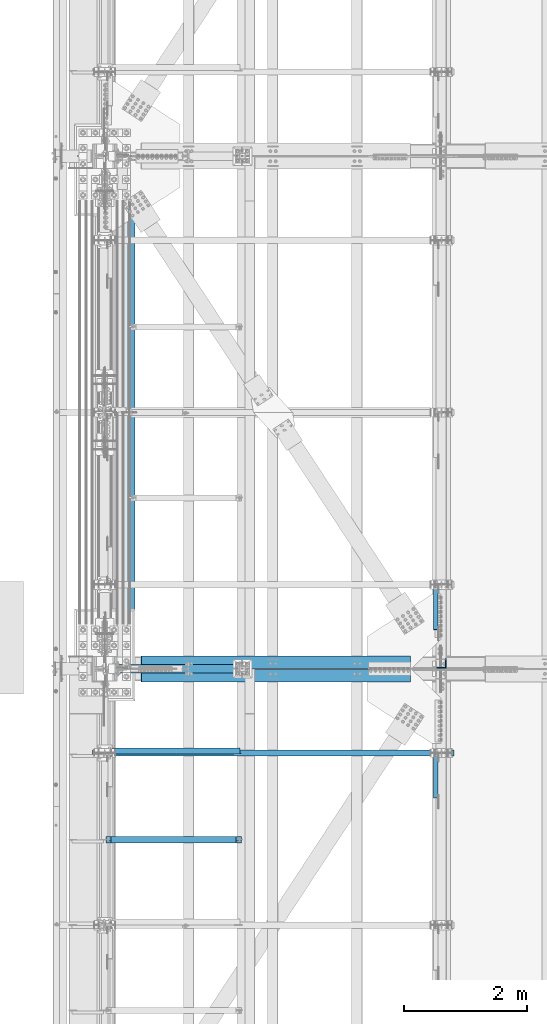
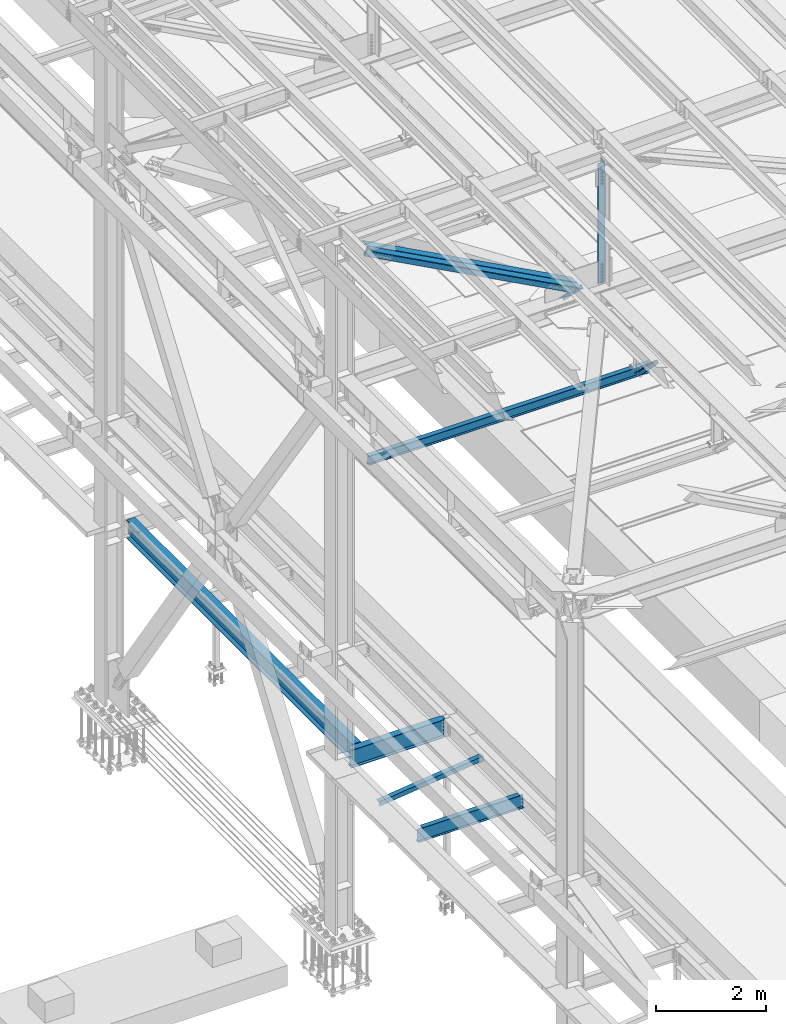
# One storey, part 1814 of 3843: 6 beams, 4 members, 10 elements without a shape of their own.
"""IFC2X3 building model written with IfcOpenShell, lengths in millimetres."""

from ifc_helpers import new_model, si_unit, frame, origin_with_axes, place, context, subcontext, project, spatial, faceted_brep, material, type_object, element, aggregate, save


model = new_model("IFC2X3")

# Units and contexts
model_context = context("Model", 3, precision=1e-05, world=origin_with_axes())
body_context = subcontext(model_context, "Body", "Model", "MODEL_VIEW")
ifc_project = project(units=[si_unit("LENGTHUNIT", "METRE", prefix="MILLI"), si_unit("AREAUNIT", "SQUARE_METRE"), si_unit("VOLUMEUNIT", "CUBIC_METRE"), si_unit("MASSUNIT", "GRAM", prefix="KILO"), si_unit("TIMEUNIT", "SECOND"), si_unit("PLANEANGLEUNIT", "RADIAN"), si_unit("SOLIDANGLEUNIT", "STERADIAN"), si_unit("THERMODYNAMICTEMPERATUREUNIT", "DEGREE_CELSIUS"), si_unit("LUMINOUSINTENSITYUNIT", "LUMEN")], contexts=[model_context])

# Site, building, storey
site_placement = place(None, origin_with_axes())
site = spatial("IfcSite", under=ifc_project, at=site_placement, CompositionType="ELEMENT")
building_placement = place(site_placement, origin_with_axes())
building = spatial("IfcBuilding", under=site, at=building_placement, Name="Undefined", CompositionType="ELEMENT")
storey_placement = place(building_placement, origin_with_axes())
storey = spatial("IfcBuildingStorey", under=building, at=storey_placement, Name="Undefined", CompositionType="ELEMENT", Elevation=0.0)

# Assembly, beam
assembly_1_placement = place(storey_placement, origin_with_axes())
assembly_1 = element("IfcElementAssembly", 1, at=assembly_1_placement, inside=storey, Name="ANGLE", AssemblyPlace="NOTDEFINED", PredefinedType="RIGID_FRAME")
ifc_material_1 = material(Name="STEEL/A572-50")
beam_type_1 = type_object("IfcBeamType", Name="L4X4X3/8", PredefinedType="NOTDEFINED")
beam_1_placement = place(assembly_1_placement, frame((38788.5093206542, 49219.842188, 33960.1419503901), z_axis=(0.0, 1.0, 0.0), x_axis=(-0.993268693078032, 0.0, -0.115833084009098)))
beam_1 = element("IfcBeam", 2, at=beam_1_placement, type_object=beam_type_1, material=ifc_material_1, Name="ANGLE", ObjectType="L4X4X3/8", context=body_context, shape_type="Brep", body=[
    faceted_brep([(0.0, 50.8000000000029, -50.8000000000029), (0.0, 50.8000000000029, 50.8000000000029), (2192.8104802954, 50.7999999940694, 50.8000000000029), (2192.8104802954, 50.7999999940694, -50.8000000000029), (0.0, 41.2750000000015, 50.8000000000029), (2192.81048029537, 41.2749999940788, 50.8000000000029), (0.0, 41.2749999999942, -41.2750000000015), (2192.81048029537, 41.2749999940788, -41.2750000000015), (0.0, -50.8000000000029, -41.2750000000015), (2192.81048029512, -50.8000000058528, -41.2750000000015), (0.0, -50.8000000000029, -50.8000000000029), (2192.81048029512, -50.8000000058528, -50.8000000000029)], [[[0, 1, 2, 3]], [[1, 4, 5, 2]], [[4, 6, 7, 5]], [[6, 8, 9, 7]], [[8, 10, 11, 9]], [[10, 0, 3, 11]], [[5, 7, 9, 11, 3, 2]], [[10, 8, 6, 4, 1, 0]]]),
])
aggregate(assembly_1, [beam_1])

# Assembly, member
assembly_2_placement = place(storey_placement, origin_with_axes())
assembly_2 = element("IfcElementAssembly", 3, at=assembly_2_placement, inside=storey, Name="ANGLE", AssemblyPlace="NOTDEFINED", PredefinedType="RIGID_FRAME")
member_type_1 = type_object("IfcMemberType", Name="L3X3X1/4", PredefinedType="NOTDEFINED")
member_1_placement = place(assembly_2_placement, frame((41973.5, 48180.1041568663, 42307.3958431337), z_axis=(0.0, -0.707106781186548, -0.707106781186548), x_axis=(5.70000238222118e-08, 0.707106781186546, -0.707106781186546)))
member_1 = element("IfcMember", 4, at=member_1_placement, type_object=member_type_1, material=ifc_material_1, Name="ANGLE", ObjectType="L3X3X1/4", context=body_context, shape_type="Brep", body=[
    faceted_brep([(1341.10589794551, -38.0999999999985, -31.74999999992), (1341.10589794551, -38.0999999999985, -38.0999999999112), (1341.10589794551, 38.0999999999985, -38.0999999999112), (1341.10589794551, 38.0999999999985, 38.099999999904), (1341.10589794551, 31.75, 38.099999999904), (1341.10589794551, 31.75, -31.74999999992), (350.505897945443, 31.75, 38.0999999999112), (350.505897945436, 31.75, -31.7499999999272), (350.505897945436, -38.0999999999985, -31.7499999999272), (350.505897945436, -38.0999999999985, -38.099999999904), (350.505897945436, 38.0999999999985, -38.099999999904), (350.505897945443, 38.0999999999985, 38.0999999999112)], [[[0, 1, 2, 3, 4, 5]], [[5, 4, 6, 7]], [[0, 5, 7, 8]], [[1, 0, 8, 9]], [[2, 1, 9, 10]], [[3, 2, 10, 11]], [[4, 3, 11, 6]], [[10, 9, 8, 7, 6, 11]]]),
])
aggregate(assembly_2, [member_1])

assembly_3_placement = place(storey_placement, origin_with_axes())
assembly_3 = element("IfcElementAssembly", 5, at=assembly_3_placement, inside=storey, Name="ANGLE", AssemblyPlace="NOTDEFINED", PredefinedType="RIGID_FRAME")
member_2_placement = place(assembly_3_placement, frame((41973.5, 50919.1053209837, 42311.5946790162), z_axis=(0.0, -0.707106781186548, -0.707106781186548), x_axis=(5.70000238222118e-08, 0.707106781186546, -0.707106781186546)))
member_2 = element("IfcMember", 6, at=member_2_placement, type_object=member_type_1, material=ifc_material_1, Name="ANGLE", ObjectType="L3X3X1/4", context=body_context, shape_type="Brep", body=[
    faceted_brep([(1347.04394859672, -38.0999999999985, -31.7499999999272), (1347.04394859672, -38.0999999999985, -38.099999999904), (1347.04394859672, 38.0999999999985, -38.099999999904), (1347.04394859672, 38.0999999999985, 38.099999999904), (1347.04394859672, 31.75, 38.099999999904), (1347.04394859672, 31.75, -31.7499999999272), (356.44394859662, 31.75, 38.099999999904), (356.44394859663, 31.75, -31.7499999999272), (356.44394859663, -38.0999999999985, -31.7499999999272), (356.443948596627, -38.0999999999985, -38.099999999904), (356.443948596627, 38.0999999999985, -38.099999999904), (356.44394859662, 38.0999999999985, 38.099999999904)], [[[0, 1, 2, 3, 4, 5]], [[5, 4, 6, 7]], [[0, 5, 7, 8]], [[1, 0, 8, 9]], [[2, 1, 9, 10]], [[3, 2, 10, 11]], [[4, 3, 11, 6]], [[10, 9, 8, 7, 6, 11]]]),
])
aggregate(assembly_3, [member_2])

# Assembly, beam
assembly_4_placement = place(storey_placement, origin_with_axes())
assembly_4 = element("IfcElementAssembly", 7, at=assembly_4_placement, inside=storey, Name="BEAM", AssemblyPlace="NOTDEFINED", PredefinedType="RIGID_FRAME")
ifc_material_2 = material(Name="STEEL/A992")
beam_type_2 = type_object("IfcBeamType", Name="W8X13", PredefinedType="NOTDEFINED")
beam_2_placement = place(assembly_4_placement, frame((36372.8, 49187.1, 41402.0), z_axis=(0.0, 0.0, 1.0), x_axis=(1.0, 0.0, 0.0)))
beam_2 = element("IfcBeam", 8, at=beam_2_placement, type_object=beam_type_2, material=ifc_material_2, Name="BEAM", ObjectType="W8X13", context=body_context, shape_type="Brep", body=[
    faceted_brep([(0.0, 50.7999999999993, -101.599999999999), (0.0, 50.7999999999993, -95.25), (5892.8, 50.7999999999993, -95.25), (5892.8, 50.7999999999993, -101.599999999999), (0.0, 3.17499999999927, -95.25), (5892.8, 3.17499999999927, -95.25), (-2.44140610448085e-05, 3.17500000000291, 95.2499999999927), (5892.8, 3.17499999999927, 95.25), (0.0, 50.7999999999993, 95.25), (5892.8, 50.7999999999993, 95.25), (0.0, 50.7999999999993, 101.599999999999), (5892.8, 50.7999999999993, 101.599999999999), (0.0, -50.7999999999993, 101.599999999999), (5892.8, -50.7999999999993, 101.599999999999), (0.0, -50.7999999999993, 95.25), (5892.8, -50.7999999999993, 95.25), (0.0, -3.17499999999927, 95.25), (5892.8, -3.17499999999927, 95.25), (0.0, -3.17499999999927, -95.25), (5892.8, -3.17499999999927, -95.25), (0.0, -50.7999999999993, -95.25), (5892.8, -50.7999999999993, -95.25), (0.0, -50.7999999999993, -101.599999999999), (5892.8, -50.7999999999993, -101.599999999999)], [[[0, 1, 2, 3]], [[1, 4, 5, 2]], [[4, 6, 7, 5]], [[6, 8, 9, 7]], [[8, 10, 11, 9]], [[10, 12, 13, 11]], [[12, 14, 15, 13]], [[14, 16, 17, 15]], [[16, 18, 19, 17]], [[18, 20, 21, 19]], [[20, 22, 23, 21]], [[22, 0, 3, 23]], [[5, 7, 9, 11, 13, 15, 17, 19, 21, 23, 3, 2]], [[22, 20, 18, 16, 14, 12, 10, 8, 6, 4, 1, 0]]]),
])
aggregate(assembly_4, [beam_2])

# Assembly, member
assembly_5_placement = place(storey_placement, origin_with_axes())
assembly_5 = element("IfcElementAssembly", 9, at=assembly_5_placement, inside=storey, Name="ANGLE", AssemblyPlace="NOTDEFINED", PredefinedType="RIGID_FRAME")
member_type_2 = type_object("IfcMemberType", Name="L8X8X1/2", PredefinedType="NOTDEFINED")
member_3_placement = place(assembly_5_placement, frame((36576.0000011999, 50669.825, 45221.4524483094), z_axis=(-0.472865886796398, 0.0, -0.881134412620604), x_axis=(0.881134412620605, 0.0, -0.472865886796396)))
member_3 = element("IfcMember", 10, at=member_3_placement, type_object=member_type_2, material=ifc_material_1, Name="ANGLE", ObjectType="L8X8X1/2", context=body_context, shape_type="Brep", body=[
    faceted_brep([(625.570468447338, 101.599999999999, -101.600000000588), (625.570468447342, 101.599999999999, 101.600000000028), (5601.70349408219, 101.599999999999, 101.599999997765), (5601.70349408219, 101.599999999999, -101.600000002851), (625.570468447342, 88.9000000000015, 101.600000000028), (5601.70349408219, 88.9000000000015, 101.599999997765), (625.570468447338, 88.9000000000015, -88.9000000005617), (5601.70349408219, 88.9000000000015, -88.9000000028173), (625.570468447338, -101.599999999999, -88.9000000005617), (5601.70349408219, -101.599999999999, -88.9000000028173), (625.570468447338, -101.599999999999, -101.600000000588), (5601.70349408219, -101.599999999999, -101.600000002851)], [[[0, 1, 2, 3]], [[1, 4, 5, 2]], [[4, 6, 7, 5]], [[6, 8, 9, 7]], [[8, 10, 11, 9]], [[10, 0, 3, 11]], [[5, 7, 9, 11, 3, 2]], [[10, 8, 6, 4, 1, 0]]]),
])
aggregate(assembly_5, [member_3])

assembly_6_placement = place(storey_placement, origin_with_axes())
assembly_6 = element("IfcElementAssembly", 11, at=assembly_6_placement, inside=storey, Name="ANGLE", AssemblyPlace="NOTDEFINED", PredefinedType="RIGID_FRAME")
member_4_placement = place(assembly_6_placement, frame((42062.3999982764, 50447.575, 42277.1408504695), z_axis=(-0.472865886796398, 0.0, -0.881134412620604), x_axis=(-0.881134412620606, 0.0, 0.472865886796394)))
member_4 = element("IfcMember", 12, at=member_4_placement, type_object=member_type_2, material=ifc_material_1, Name="ANGLE", ObjectType="L8X8X1/2", context=body_context, shape_type="Brep", body=[
    faceted_brep([(624.816859499602, 101.599999999999, -101.600000000042), (624.81685949961, 101.599999999999, 101.600000000581), (5600.94988513445, 101.599999999999, 101.600000002836), (5600.94988513445, 101.599999999999, -101.599999997779), (624.81685949961, 88.9000000000015, 101.600000000581), (5600.94988513445, 88.9000000000015, 101.600000002836), (624.81685949961, 88.9000000000015, -88.8999999999942), (5600.94988513445, 88.9000000000015, -88.8999999977386), (624.81685949961, -101.599999999999, -88.8999999999942), (5600.94988513445, -101.599999999999, -88.8999999977386), (624.816859499602, -101.599999999999, -101.600000000042), (5600.94988513445, -101.599999999999, -101.599999997779)], [[[0, 1, 2, 3]], [[1, 4, 5, 2]], [[4, 6, 7, 5]], [[6, 8, 9, 7]], [[8, 10, 11, 9]], [[10, 0, 3, 11]], [[5, 7, 9, 11, 3, 2]], [[10, 8, 6, 4, 1, 0]]]),
])
aggregate(assembly_6, [member_4])

# Assembly, beam
assembly_7_placement = place(storey_placement, origin_with_axes())
assembly_7 = element("IfcElementAssembly", 13, at=assembly_7_placement, inside=storey, Name="ANGLE", AssemblyPlace="NOTDEFINED", PredefinedType="RIGID_FRAME")
beam_type_3 = type_object("IfcBeamType", Name="L6X6X1/2", PredefinedType="NOTDEFINED")
beam_3_placement = place(assembly_7_placement, frame((42062.4, 50644.4249999998, 45368.1453900545), z_axis=(-1.0, 0.0, 0.0), x_axis=(0.0, 0.0, -1.0)))
beam_3 = element("IfcBeam", 14, at=beam_3_placement, type_object=beam_type_3, material=ifc_material_1, Name="ANGLE", ObjectType="L6X6X1/2", context=body_context, shape_type="Brep", body=[
    faceted_brep([(224.846683648051, 76.1999999999971, -76.2000000007174), (224.846683648051, 76.1999999999971, 76.1999999992768), (2881.85056894296, 76.1999999999971, 76.1999999908003), (2881.85056894296, 76.1999999999971, -76.2000000092012), (224.846683648051, 63.5, 76.1999999992768), (2881.85056894296, 63.5, 76.1999999908003), (224.846683648044, 63.5, -63.5000000007203), (2881.85056894295, 63.5, -63.5000000091968), (224.846683648044, -76.1999999999971, -63.5000000007203), (2881.85056894295, -76.1999999999971, -63.5000000091968), (224.846683648051, -76.1999999999971, -76.2000000007174), (2881.85056894296, -76.1999999999971, -76.2000000092012)], [[[0, 1, 2, 3]], [[1, 4, 5, 2]], [[4, 6, 7, 5]], [[6, 8, 9, 7]], [[8, 10, 11, 9]], [[10, 0, 3, 11]], [[5, 7, 9, 11, 3, 2]], [[10, 8, 6, 4, 1, 0]]]),
])
aggregate(assembly_7, [beam_3])

assembly_8_placement = place(storey_placement, origin_with_axes())
assembly_8 = element("IfcElementAssembly", 15, at=assembly_8_placement, inside=storey, Name="BEAM", AssemblyPlace="NOTDEFINED", PredefinedType="RIGID_FRAME")
beam_type_4 = type_object("IfcBeamType", Name="W16X40", PredefinedType="NOTDEFINED")
beam_4_placement = place(assembly_8_placement, frame((36982.4, 50558.7, 33832.8), z_axis=(0.0, 0.0, 1.0), x_axis=(0.0, 1.0, 0.0)))
beam_4 = element("IfcBeam", 16, at=beam_4_placement, type_object=beam_type_4, material=ifc_material_2, Name="BEAM", ObjectType="W16X40", context=body_context, shape_type="Brep", body=[
    faceted_brep([(15.875, -3.96875, -171.709999999999), (15.875, 3.96875, -171.709999999999), (73.0249997176288, 3.96875, -171.709999999999), (73.0249997176288, -3.96875, -171.709999999999), (77.8850792356679, 3.96875, -172.67672992259), (77.8850792356679, -3.96875, -172.67672992259), (82.0052557038289, 3.96875, -175.429743823064), (82.0052557038289, -3.96875, -175.429743823064), (84.75826960431, 3.96875, -179.549920291218), (84.75826960431, -3.96875, -179.549920291218), (85.724999526894, -3.96875, -184.409999809264), (85.724999526894, 3.96875, -184.409999809264), (85.724999526894, 3.96875, -190.5), (85.724999526894, 88.9000000000015, -190.5), (85.724999526894, 88.9000000000015, -203.199999999997), (85.724999526894, -88.9000000000015, -203.199999999997), (85.724999526894, -88.9000000000015, -190.5), (85.724999526894, -3.96875, -190.5), (85.724999063299, 3.96875, 190.5), (85.724999063299, 88.9000000000015, 190.5), (8270.87500093675, 88.9000000000015, 190.5), (8270.87500093675, 3.96875, 190.5), (73.0249992540339, -3.96875, 177.54000167847), (73.0249992540339, 3.96875, 177.54000167847), (15.875, 3.96875, 177.54000167847), (15.875, -3.96875, 177.54000167847), (77.885078772073, -3.96875, 178.506731601061), (77.885078772073, 3.96875, 178.506731601061), (82.005255240234, -3.96875, 181.259745501535), (82.005255240234, 3.96875, 181.259745501535), (84.7582691407151, -3.96875, 185.379921969688), (84.7582691407151, 3.96875, 185.379921969688), (85.724999063299, -3.96875, 190.240001487735), (85.724999063299, 3.96875, 190.240001487735), (85.724999063299, 88.9000000000015, 203.199999999997), (85.724999063299, -88.9000000000015, 203.199999999997), (8270.87500093675, -88.9000000000015, 203.199999999997), (8270.87500093675, 88.9000000000015, 203.199999999997), (85.724999063299, -88.9000000000015, 190.5), (8270.87500093675, -88.9000000000015, 190.5), (85.724999063299, -3.96875, 190.5), (8270.87500093675, -3.96875, 190.5), (8270.87500093675, -3.96875, 190.240001487735), (8270.87500093675, 3.96875, 190.240001487735), (8271.84173085933, -3.96875, 185.379921969688), (8271.84173085933, 3.96875, 185.379921969688), (8274.59474475982, -3.96875, 181.259745501535), (8274.59474475982, 3.96875, 181.259745501535), (8278.71492122798, -3.96875, 178.506731601061), (8278.71492122798, 3.96875, 178.506731601061), (8283.57500074602, -3.96875, 177.54000167847), (8283.57500074602, 3.96875, 177.54000167847), (8340.72500000001, -3.96875, 177.54000167847), (8340.72500000001, 3.96875, 177.54000167847), (8340.72500000001, -3.96875, -171.709999999999), (8340.72500000001, 3.96875, -171.709999999999), (8283.57500028238, -3.96875, -171.709999999999), (8283.57500028238, 3.96875, -171.709999999999), (8278.71492076434, -3.96875, -172.67672992259), (8278.71492076434, 3.96875, -172.67672992259), (8274.59474429618, -3.96875, -175.429743823064), (8274.59474429618, 3.96875, -175.429743823064), (8271.84173039571, -3.96875, -179.549920291225), (8271.84173039571, 3.96875, -179.549920291225), (8270.87500047311, -3.96875, -184.409999809272), (8270.87500047311, 3.96875, -184.409999809272), (8270.87500047311, -3.96875, -190.5), (8270.87500047311, -88.9000000000015, -190.5), (8270.87500047313, -88.9000000000015, -203.199999999997), (8270.87500047313, 88.9000000000015, -203.199999999997), (8270.87500047311, 88.9000000000015, -190.5), (8270.87500047311, 3.96875, -190.5)], [[[0, 1, 2, 3]], [[3, 2, 4, 5]], [[5, 4, 6, 7]], [[7, 6, 8, 9]], [[10, 11, 12, 13, 14, 15, 16, 17]], [[9, 8, 11, 10]], [[18, 19, 20, 21]], [[22, 23, 24, 25]], [[26, 27, 23, 22]], [[28, 29, 27, 26]], [[30, 31, 29, 28]], [[32, 33, 31, 30]], [[34, 35, 36, 37]], [[35, 38, 39, 36]], [[38, 40, 41, 39]], [[35, 34, 19, 18, 33, 32, 40, 38]], [[19, 34, 37, 20]], [[36, 39, 41, 42, 43, 21, 20, 37]], [[44, 45, 43, 42]], [[46, 47, 45, 44]], [[48, 49, 47, 46]], [[50, 51, 49, 48]], [[52, 53, 51, 50]], [[53, 52, 54, 55]], [[54, 56, 57, 55]], [[58, 59, 57, 56]], [[60, 61, 59, 58]], [[62, 63, 61, 60]], [[64, 65, 63, 62]], [[66, 67, 68, 69, 70, 71, 65, 64]], [[17, 16, 67, 66]], [[16, 15, 68, 67]], [[15, 14, 69, 68]], [[14, 13, 70, 69]], [[13, 12, 71, 70]], [[59, 61, 63, 65, 71, 12, 11, 8, 6, 4, 2, 1, 24, 23, 27, 29, 31, 33, 18, 21, 43, 45, 47, 49, 51, 53, 55, 57]], [[25, 24, 1, 0]], [[52, 50, 48, 46, 44, 42, 41, 40, 32, 30, 28, 26, 22, 25, 0, 3, 5, 7, 9, 10, 17, 66, 64, 62, 60, 58, 56, 54]]]),
])
aggregate(assembly_8, [beam_4])

assembly_9_placement = place(storey_placement, origin_with_axes())
assembly_9 = element("IfcElementAssembly", 17, at=assembly_9_placement, inside=storey, Name="BEAM", AssemblyPlace="NOTDEFINED", PredefinedType="RIGID_FRAME")
beam_type_5 = type_object("IfcBeamType", Name="W16X26", PredefinedType="NOTDEFINED")
beam_5_placement = place(assembly_9_placement, frame((36576.0, 50558.7, 33835.975), z_axis=(0.0, 0.0, 1.0), x_axis=(1.0, 0.0, 0.0)))
beam_5 = element("IfcBeam", 18, at=beam_5_placement, type_object=beam_type_5, material=ifc_material_2, Name="BEAM", ObjectType="W16X26", context=body_context, shape_type="Brep", body=[
    faceted_brep([(2130.42500076294, 50.8000007629307, 200.025000000016), (2130.42500076294, 50.8000007629307, 190.5), (2130.42500076294, 69.8500000000058, 190.5), (2130.42500076294, 69.8500000000058, 200.025000000001), (2181.22500000001, 50.8000007629307, 200.025000000016), (2181.225, 50.8000007629307, 190.5), (2130.42500076294, 50.8000007629307, -190.5), (2130.42500076294, 50.8000007629307, -200.025000000001), (2130.42500076294, 69.8500000000058, -200.025000000001), (2130.42500076294, 69.8500000000058, -190.5), (2181.22500000001, 50.8000007629307, -190.5), (2181.225, 50.8000007629307, -200.025000000001), (2130.42500076294, -69.8500000000058, -190.5), (2130.42500076294, -69.8500000000058, -200.025000000001), (2130.42500076294, -50.8000007629307, -200.025000000001), (2130.42500076294, -50.8000007629307, -190.5), (212.724999999999, -69.8500000000058, -190.5), (212.724999999999, -69.8500000000058, -200.025000000001), (2130.42500076294, -69.8500000000058, 200.025000000001), (2130.42500076294, -69.8500000000058, 190.5), (2130.42500076294, -50.8000007629307, 190.5), (2130.42500076294, -50.8000007629307, 200.025000000016), (212.724999999999, -69.8500000000058, 200.025000000001), (212.724999999999, -69.8500000000058, 190.5), (212.724999999999, -3.17500000000291, -190.5), (212.724999999999, -3.17500000000291, 190.5), (212.724999999999, 69.8500000000058, 200.025000000001), (212.724999999999, 69.8500000000058, 190.5), (212.724999999999, 3.17500000000291, 190.5), (212.724999999999, 3.17500000000291, -190.5), (212.724999999999, 69.8500000000058, -190.5), (212.724999999999, 69.8500000000058, -200.025000000001), (2181.225, 3.17500000000291, 190.5), (2181.225, 3.17500000000291, -190.5), (2181.225, -50.8000007629307, -200.025000000001), (2181.22500000001, -50.8000007629307, -190.5), (2181.225, -3.17500000000291, -190.5), (2181.225, -3.17500000000291, 190.5), (2181.225, -50.8000007629307, 190.5), (2181.22500000001, -50.8000007629307, 200.025000000016)], [[[0, 1, 2, 3]], [[4, 5, 1, 0]], [[6, 7, 8, 9]], [[10, 11, 7, 6]], [[12, 13, 14, 15]], [[16, 17, 13, 12]], [[18, 19, 20, 21]], [[22, 23, 19, 18]], [[17, 16, 24, 25, 23, 22, 26, 27, 28, 29, 30, 31]], [[27, 26, 3, 2]], [[32, 28, 27, 2, 1, 5]], [[29, 28, 32, 33]], [[9, 30, 29, 33, 10, 6]], [[31, 30, 9, 8]], [[34, 14, 13, 17, 31, 8, 7, 11]], [[35, 15, 14, 34]], [[36, 24, 16, 12, 15, 35]], [[25, 24, 36, 37]], [[19, 23, 25, 37, 38, 20]], [[39, 21, 20, 38]], [[3, 26, 22, 18, 21, 39, 4, 0]], [[39, 38, 37, 36, 35, 34, 11, 10, 33, 32, 5, 4]]]),
])
aggregate(assembly_9, [beam_5])

assembly_10_placement = place(storey_placement, origin_with_axes())
assembly_10 = element("IfcElementAssembly", 19, at=assembly_10_placement, inside=storey, Name="BEAM", AssemblyPlace="NOTDEFINED", PredefinedType="RIGID_FRAME")
beam_type_6 = type_object("IfcBeamType", Name="W12X14", PredefinedType="NOTDEFINED")
beam_6_placement = place(assembly_10_placement, frame((36576.0, 47773.034376, 33885.1875), z_axis=(0.0, 0.0, 1.0), x_axis=(1.0, 0.0, 0.0)))
beam_6 = element("IfcBeam", 20, at=beam_6_placement, type_object=beam_type_6, material=ifc_material_2, Name="BEAM", ObjectType="W12X14", context=body_context, shape_type="Brep", body=[
    faceted_brep([(92.8687501907334, -2.38125000000582, 125.412499999991), (92.8687501907334, 2.38125000000582, 125.412499999991), (16.6687499999971, 2.38125000000582, 125.412499999991), (16.6687499999971, -2.38125000000582, 125.412499999991), (97.7288297087798, -2.38125000000582, 126.379229922582), (97.7288297087798, 2.38125000000582, 126.379229922582), (101.849006176933, -2.38125000000582, 129.132243823056), (101.849006176933, 2.38125000000582, 129.132243823056), (104.602020077407, -2.38125000000582, 133.25242029121), (104.602020077407, 2.38125000000582, 133.25242029121), (105.568749999999, -2.38125000000582, 138.112499809256), (105.568749999999, 2.38125000000582, 138.112499809256), (105.568749999999, -50.8000000000029, 150.812499810811), (105.568749999999, 50.8000000000029, 150.8125), (105.568749999999, 50.8000000000029, 144.462500000001), (105.568749999999, 2.38125000000582, 144.462500000001), (105.568749999999, -2.38125000000582, 144.462500000001), (105.568749999999, -50.8000000000029, 144.462500000001), (16.6687499999971, -2.38125000000582, -144.462500000001), (16.6687499999971, -50.7999999999993, -144.462500000001), (2228.05625, -50.8000000000029, -144.462500000001), (2228.05625, -2.38125000000582, -144.462500000001), (16.6687499999971, -50.8000000000029, -150.8125), (2228.05625, -50.8000000000029, -150.8125), (16.6687499999971, 50.8000000000029, -150.8125), (2228.05625, 50.8000000000029, -150.8125), (16.6687499999971, 50.7999999999993, -144.462500000001), (2228.05625, 50.8000000000029, -144.462500000001), (16.6687499999971, 2.38125000000582, -144.462500000001), (2228.05625, 2.38125000000582, -144.462500000001), (2228.05625, 2.38125000000582, -117.887499999997), (2228.05625, 2.38125000000582, 112.712500000001), (2228.05625, 2.38125000000582, 125.412499999991), (2228.05625, -2.38125000000582, 125.412499999991), (2151.85624980927, 2.38125000000582, 125.412499999991), (2151.85624980927, -2.38125000000582, 125.412499999991), (2146.99617029122, 2.38125000000582, 126.379229922582), (2146.99617029122, -2.38125000000582, 126.379229922582), (2142.87599382307, 2.38125000000582, 129.132243823056), (2142.87599382307, -2.38125000000582, 129.132243823056), (2140.12297992259, 2.38125000000582, 133.25242029121), (2140.12297992259, -2.38125000000582, 133.25242029121), (2139.15625, 2.38125000000582, 138.112499809256), (2139.15625, -2.38125000000582, 138.112499809256), (2139.15625, -50.8000000000029, 150.8125), (2139.15625, -50.8000000000029, 144.462500000001), (2139.15625, -2.38125000000582, 144.462500000001), (2139.15625, 2.38125000000582, 144.462500000001), (2139.15625, 50.8000000000029, 144.462500000001), (2139.15625, 50.8000000000029, 150.8125), (16.6687499999971, 2.38125000000582, 112.712500000001), (16.6687499999971, 2.38125000000582, -117.887499999997)], [[[0, 1, 2, 3]], [[4, 5, 1, 0]], [[6, 7, 5, 4]], [[8, 9, 7, 6]], [[10, 11, 9, 8]], [[12, 13, 14, 15, 11, 10, 16, 17]], [[18, 19, 20, 21]], [[19, 22, 23, 20]], [[22, 24, 25, 23]], [[24, 26, 27, 25]], [[26, 28, 29, 27]], [[21, 20, 23, 25, 27, 29, 30, 31, 32, 33]], [[33, 32, 34, 35]], [[35, 34, 36, 37]], [[37, 36, 38, 39]], [[39, 38, 40, 41]], [[41, 40, 42, 43]], [[44, 45, 46, 43, 42, 47, 48, 49]], [[45, 44, 12, 17]], [[46, 45, 17, 16]], [[8, 6, 4, 0, 3, 18, 21, 33, 35, 37, 39, 41, 43, 46, 16, 10]], [[50, 51, 28, 26, 24, 22, 19, 18, 3, 2]], [[47, 42, 40, 38, 36, 34, 32, 31, 30, 29, 28, 51, 50, 2, 1, 5, 7, 9, 11, 15]], [[48, 47, 15, 14]], [[49, 48, 14, 13]], [[44, 49, 13, 12]]]),
])
aggregate(assembly_10, [beam_6])

save(model, "model.ifc")
